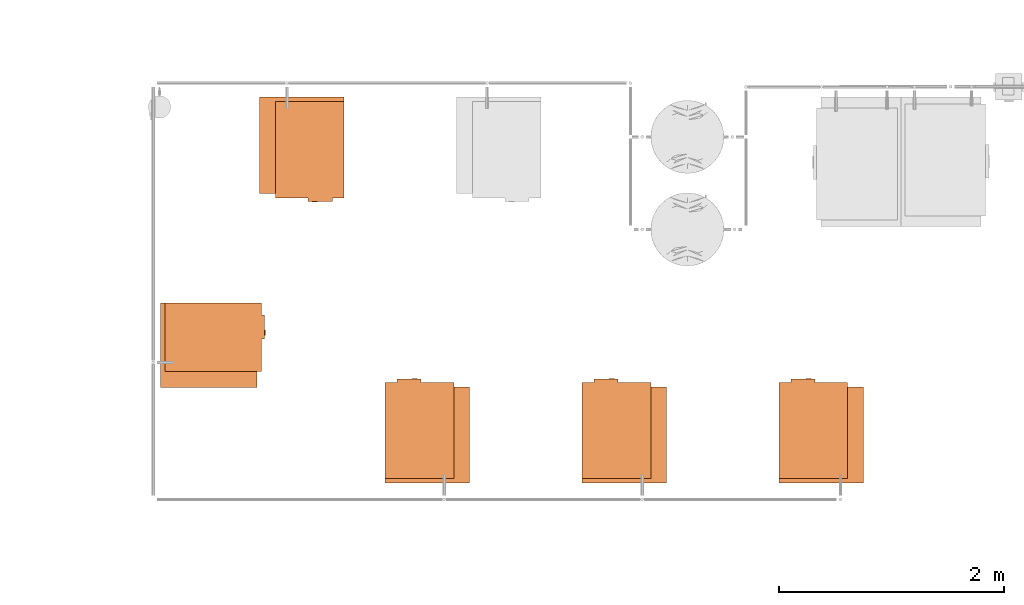
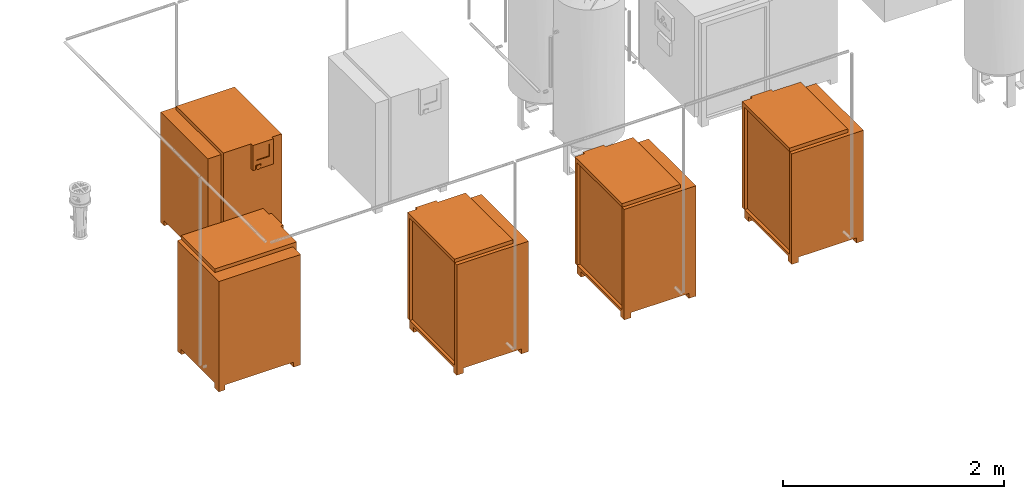
# One storey, part 325 of 331: 5 proxies.
"""IFC2X3 building model written with IfcOpenShell, lengths in millimetres."""

from ifc_helpers import new_model, entity, si_unit, converted_unit, derived_unit, direction, frame, origin, place, context, subcontext, project, spatial, faceted_brep, source, transform, mapped, material, material_list, type_object, type_shapes, element, save


model = new_model("IFC2X3")

# Units and contexts
model_context = context("Model", 3, precision=0.01, world=origin(), true_north=direction((6.12303176911189e-17, 1.0)))
body_context = subcontext(model_context, "Body", "Model", "MODEL_VIEW")
ifc_project = project(units=[si_unit("LENGTHUNIT", "METRE", prefix="MILLI"), si_unit("AREAUNIT", "SQUARE_METRE"), si_unit("VOLUMEUNIT", "CUBIC_METRE"), converted_unit("PLANEANGLEUNIT", "DEGREE", entity("IfcRatioMeasure", 0.0174532925199433), si_unit("PLANEANGLEUNIT", "RADIAN"), dimensions=[0, 0, 0, 0, 0, 0, 0]), si_unit("MASSUNIT", "GRAM", prefix="KILO"), derived_unit("MASSDENSITYUNIT", [(si_unit("MASSUNIT", "GRAM", prefix="KILO"), 1), (si_unit("LENGTHUNIT", "METRE"), -3)]), derived_unit("MOMENTOFINERTIAUNIT", [(si_unit("LENGTHUNIT", "METRE"), 4)]), si_unit("TIMEUNIT", "SECOND"), si_unit("FREQUENCYUNIT", "HERTZ"), si_unit("THERMODYNAMICTEMPERATUREUNIT", "DEGREE_CELSIUS"), derived_unit("THERMALTRANSMITTANCEUNIT", [(si_unit("MASSUNIT", "GRAM", prefix="KILO"), 1), (si_unit("THERMODYNAMICTEMPERATUREUNIT", "KELVIN"), -1), (si_unit("TIMEUNIT", "SECOND"), -3)]), derived_unit("VOLUMETRICFLOWRATEUNIT", [(si_unit("LENGTHUNIT", "METRE"), 3), (si_unit("TIMEUNIT", "SECOND"), -1)]), derived_unit("MASSFLOWRATEUNIT", [(si_unit("MASSUNIT", "GRAM", prefix="KILO"), 1), (si_unit("TIMEUNIT", "SECOND"), -1)]), derived_unit("ROTATIONALFREQUENCYUNIT", [(si_unit("TIMEUNIT", "SECOND"), -1)]), si_unit("ELECTRICCURRENTUNIT", "AMPERE"), si_unit("ELECTRICVOLTAGEUNIT", "VOLT"), si_unit("POWERUNIT", "WATT"), si_unit("FORCEUNIT", "NEWTON", prefix="KILO"), si_unit("ILLUMINANCEUNIT", "LUX"), si_unit("LUMINOUSFLUXUNIT", "LUMEN"), si_unit("LUMINOUSINTENSITYUNIT", "CANDELA"), derived_unit("USERDEFINED", [(si_unit("MASSUNIT", "GRAM", prefix="KILO"), -1), (si_unit("LENGTHUNIT", "METRE"), -2), (si_unit("TIMEUNIT", "SECOND"), 3), (si_unit("LUMINOUSFLUXUNIT", "LUMEN"), 1)]), derived_unit("LINEARVELOCITYUNIT", [(si_unit("LENGTHUNIT", "METRE"), 1), (si_unit("TIMEUNIT", "SECOND"), -1)]), si_unit("PRESSUREUNIT", "PASCAL"), derived_unit("USERDEFINED", [(si_unit("LENGTHUNIT", "METRE"), -2), (si_unit("MASSUNIT", "GRAM", prefix="KILO"), 1), (si_unit("TIMEUNIT", "SECOND"), -2)]), derived_unit("LINEARFORCEUNIT", [(si_unit("MASSUNIT", "GRAM", prefix="KILO"), 1), (si_unit("LENGTHUNIT", "METRE"), 1), (si_unit("TIMEUNIT", "SECOND"), -2), (si_unit("LENGTHUNIT", "METRE"), -1)]), derived_unit("PLANARFORCEUNIT", [(si_unit("MASSUNIT", "GRAM", prefix="KILO"), 1), (si_unit("LENGTHUNIT", "METRE"), 1), (si_unit("TIMEUNIT", "SECOND"), -2), (si_unit("LENGTHUNIT", "METRE"), -2)])], contexts=[model_context])

# Site, building, storey
site_placement = place(None, frame((0.0, -0.00077364408347762, 0.0)))
site = spatial("IfcSite", under=ifc_project, at=site_placement, CompositionType="ELEMENT")
building_placement = place(site_placement, origin())
building = spatial("IfcBuilding", under=site, at=building_placement, CompositionType="ELEMENT")
storey_placement = place(building_placement, origin())
storey = spatial("IfcBuildingStorey", under=building, at=storey_placement, CompositionType="ELEMENT", Elevation=0.0)

# Proxies
ifc_material_1 = material()
ifc_material_2 = material()
ifc_material_3 = material()
ifc_material_list_1 = material_list([ifc_material_1, ifc_material_2, ifc_material_3])
building_element_proxy_type = type_object("IfcBuildingElementProxyType", Name="SK 22:SK 22", PredefinedType="NOTDEFINED", material=ifc_material_1)
shared_shape = source(origin(), body_context, "Body", "Brep", [
    faceted_brep([(-407.500000000001, 235.0, 1220.0), (447.499999999999, 235.0, 1220.0), (447.5, 375.0, 1220.0), (-407.5, 375.0, 1220.0), (447.5, 375.0, 0.0), (447.5, 300.0, 0.0), (384.634472919975, 300.0, 0.0), (384.634472919975, 375.0, 0.0), (-407.500000000001, 235.0, 56.089418150774), (447.499999999999, 235.0, 56.089418150774), (447.499999999999, 300.0, 56.089418150774), (384.634472919975, 375.0, 56.089418150774), (-332.5, 375.0, 56.089418150774), (-332.5, 375.0, 0.0), (-407.5, 375.0, 0.0), (-407.5, 300.0, 0.0), (-407.5, 300.0, 56.089418150774), (-332.5, 300.0, 56.089418150774), (384.634472919975, 300.0, 56.089418150774), (-332.5, 300.0, 0.0)], [[[0, 1, 2, 3]], [[4, 5, 6, 7]], [[1, 0, 8, 9]], [[2, 1, 9, 10, 5, 4]], [[3, 2, 4, 7, 11, 12, 13, 14]], [[0, 3, 14, 15, 16, 8]], [[10, 9, 8, 16, 17, 12, 11, 18]], [[5, 10, 18, 6]], [[12, 17, 19, 13]], [[18, 11, 7, 6]], [[16, 15, 19, 17]], [[15, 14, 13, 19]]]),
    faceted_brep([(-483.897349584666, -118.970476127563, 982.237770655706), (-483.897349584666, -125.0, 984.735281218321), (-483.897349584666, -130.177669529664, 988.708246783269), (-483.897349584666, -134.150635094611, 993.885916312932), (-483.897349584666, -136.648145657227, 999.915440185369), (-483.897349584666, -137.5, 1006.38591631293), (-483.897349584666, -136.648145657227, 1012.8563924405), (-483.897349584666, -134.150635094611, 1018.88591631293), (-483.897349584666, -130.177669529664, 1024.0635858426), (-483.897349584666, -125.0, 1028.03655140754), (-483.897349584666, -118.970476127563, 1030.53406197016), (-483.897349584666, -112.5, 1031.38591631293), (-483.897349584666, -106.029523872437, 1030.53406197016), (-483.897349584666, -100.0, 1028.03655140754), (-483.897349584666, -94.8223304703364, 1024.0635858426), (-483.897349584666, -90.8493649053891, 1018.88591631293), (-483.897349584666, -88.3518543427734, 1012.8563924405), (-483.897349584666, -87.5, 1006.38591631293), (-483.897349584666, -88.3518543427733, 999.915440185369), (-483.897349584666, -90.849364905389, 993.885916312933), (-483.897349584666, -94.8223304703363, 988.708246783269), (-483.897349584666, -100.0, 984.735281218321), (-483.897349584666, -106.029523872437, 982.237770655706), (-483.897349584666, -112.5, 981.385916312932), (-477.500000000001, -118.970476127563, 1030.53406197016), (-477.500000000001, -125.0, 1028.03655140754), (-477.500000000001, -130.177669529664, 1024.0635858426), (-477.500000000001, -134.150635094611, 1018.88591631293), (-477.500000000001, -136.648145657227, 1012.8563924405), (-477.500000000001, -137.5, 1006.38591631293), (-477.500000000001, -136.648145657227, 999.915440185369), (-477.500000000001, -134.150635094611, 993.885916312932), (-477.500000000001, -130.177669529664, 988.708246783269), (-477.500000000001, -125.0, 984.735281218321), (-477.500000000001, -118.970476127563, 982.237770655706), (-477.500000000001, -112.5, 981.385916312932), (-477.500000000001, -106.029523872437, 982.237770655706), (-477.500000000001, -100.0, 984.735281218321), (-477.500000000001, -94.8223304703363, 988.708246783269), (-477.500000000001, -90.849364905389, 993.885916312933), (-477.500000000001, -88.3518543427733, 999.915440185369), (-477.500000000001, -87.5000000000001, 1006.38591631293), (-477.500000000001, -88.3518543427734, 1012.8563924405), (-477.500000000001, -90.8493649053891, 1018.88591631293), (-477.500000000001, -94.8223304703364, 1024.0635858426), (-477.500000000001, -100.0, 1028.03655140754), (-477.500000000001, -106.029523872437, 1030.53406197016), (-477.500000000001, -112.5, 1031.38591631293)], [[[0, 1, 2, 3, 4, 5, 6, 7, 8, 9, 10, 11, 12, 13, 14, 15, 16, 17, 18, 19, 20, 21, 22, 23]], [[24, 25, 26, 27, 28, 29, 30, 31, 32, 33, 34, 35, 36, 37, 38, 39, 40, 41, 42, 43, 44, 45, 46, 47]], [[40, 18, 17, 41]], [[39, 19, 18, 40]], [[21, 20, 38, 37]], [[39, 38, 20, 19]], [[22, 21, 37, 36]], [[23, 22, 36, 35]], [[34, 0, 23, 35]], [[33, 1, 0, 34]], [[3, 2, 32, 31]], [[33, 32, 2, 1]], [[4, 3, 31, 30]], [[5, 4, 30, 29]], [[28, 6, 5, 29]], [[27, 7, 6, 28]], [[9, 8, 26, 25]], [[27, 26, 8, 7]], [[10, 9, 25, 24]], [[11, 10, 24, 47]], [[46, 12, 11, 47]], [[45, 13, 12, 46]], [[15, 14, 44, 43]], [[45, 44, 14, 13]], [[16, 15, 43, 42]], [[17, 16, 42, 41]]]),
    faceted_brep([(-477.500000000001, -55.0, 1260.0), (-477.500000000001, -270.0, 1260.0), (-447.500000000001, -270.0, 1260.0), (-447.500000000001, -55.0, 1260.0), (-477.500000000001, -55.0, 981.385916312933), (-447.500000000001, -55.0, 981.385916312933), (-447.500000000001, -270.0, 981.385916312933), (-477.500000000001, -270.0, 981.385916312933), (-477.500000000001, -140.0, 981.385916312933), (-457.500000000001, -140.0, 981.385916312933), (-457.500000000001, -85.0, 981.385916312933), (-477.500000000001, -85.0, 981.385916312933), (-477.500000000001, -85.0, 1031.38591631293), (-477.500000000001, -140.0, 1031.38591631293), (-477.500000000001, -96.0179774809665, 1220.0), (-477.500000000001, -231.017977480966, 1220.0), (-477.500000000001, -231.017977480966, 1080.0), (-477.500000000001, -96.0179774809665, 1080.0), (-467.500000000001, -231.017977480966, 1220.0), (-467.500000000001, -96.0179774809666, 1220.0), (-467.500000000001, -96.0179774809665, 1080.0), (-467.500000000001, -231.017977480966, 1080.0), (-457.500000000001, -85.0, 1031.38591631293), (-457.500000000001, -140.0, 1031.38591631293)], [[[0, 1, 2, 3]], [[4, 5, 6, 7, 8, 9, 10, 11]], [[1, 0, 4, 11, 12, 13, 8, 7], [14, 15, 16, 17]], [[2, 1, 7, 6]], [[3, 2, 6, 5]], [[0, 3, 5, 4]], [[18, 19, 20, 21]], [[19, 18, 15, 14]], [[20, 19, 14, 17]], [[21, 20, 17, 16]], [[18, 21, 16, 15]], [[22, 10, 9, 23]], [[10, 22, 12, 11]], [[23, 9, 8, 13]], [[22, 23, 13, 12]]]),
    faceted_brep([(447.499999999998, -375.0, 1220.0), (447.499999999999, 235.0, 1220.0), (-407.500000000001, 235.0, 1220.0), (-407.500000000001, -342.939909824343, 1220.0), (407.5, -342.939909824343, 1220.0), (407.5, -375.0, 1220.0), (447.499999999998, -305.288454892349, 0.0), (447.499999999998, -375.0, 0.0), (384.634472919974, -375.0, 0.0), (384.634472919974, -305.288454892349, 0.0), (407.499999999998, -375.0, 88.1437175093115), (-407.500000000001, -375.0, 88.1437175093142), (-407.500000000001, -375.0, 0.0), (-332.500000000001, -375.0, 0.0), (-332.500000000001, -375.0, 56.089418150774), (384.634472919974, -375.0, 56.089418150774), (447.499999999998, -305.288454892349, 56.089418150774), (447.499999999999, 235.0, 56.089418150774), (-407.500000000001, 235.0, 56.089418150774), (-407.500000000001, -305.288454892347, 56.089418150774), (-407.500000000001, -305.288454892347, 0.0), (-407.500000000001, -342.939909824343, 88.1437175093142), (407.499999999998, -342.939909824343, 88.1437175093115), (384.634472919974, -305.288454892349, 56.089418150774), (-332.500000000001, -305.288454892347, 56.089418150774), (-332.500000000001, -305.288454892347, 0.0)], [[[0, 1, 2, 3, 4, 5]], [[6, 7, 8, 9]], [[7, 0, 5, 10, 11, 12, 13, 14, 15, 8]], [[1, 0, 7, 6, 16, 17]], [[2, 1, 17, 18]], [[3, 2, 18, 19, 20, 12, 11, 21]], [[21, 22, 4, 3]], [[22, 21, 11, 10]], [[4, 22, 10, 5]], [[17, 16, 23, 15, 14, 24, 19, 18]], [[20, 19, 24, 25]], [[24, 14, 13, 25]], [[15, 23, 9, 8]], [[16, 6, 9, 23]], [[12, 20, 25, 13]]]),
    faceted_brep([(407.5, 235.0, 1260.0), (-447.5, 235.0, 1260.0), (-447.500000000001, -375.0, 1260.0), (407.499999999998, -375.0, 1260.0), (-447.500000000001, -375.0, 88.1437175093128), (-447.5, 235.0, 88.1437175093128), (407.5, 235.0, 88.1437175093128), (407.499999999998, -342.939909824343, 88.1437175093128), (-407.5, -342.939909824343, 88.1437175093128), (-407.5, -375.0, 88.1437175093128), (-407.499999999999, -375.0, 1220.0), (407.499999999998, -375.0, 1220.0), (407.499999999998, -342.939909824343, 1220.0), (-407.499999999999, -342.939909824343, 1220.0)], [[[0, 1, 2, 3]], [[4, 5, 6, 7, 8, 9]], [[1, 0, 6, 5]], [[2, 1, 5, 4]], [[3, 2, 4, 9, 10, 11]], [[0, 3, 11, 12, 7, 6]], [[12, 13, 8, 7]], [[13, 12, 11, 10]], [[8, 13, 10, 9]]]),
])
type_shapes(building_element_proxy_type, [shared_shape])
proxy_1_placement = place(storey_placement, frame((46246.1118832776, -2985.00010169851, -700.0), z_axis=(0.0, 0.0, 1.0), x_axis=(-1.0, 0.0, 0.0)))
element("IfcBuildingElementProxy", 1, at=proxy_1_placement, inside=storey, type_object=building_element_proxy_type, material=ifc_material_list_1, Name="SK 22:SK 22", ObjectType="SK 22:SK 22", context=body_context, shape_type="MappedRepresentation", body=[
    mapped(shared_shape, transform((0.0, 0.0, 0.0), scale=1.0)),
])
ifc_material_list_2 = material_list([ifc_material_1, ifc_material_2, ifc_material_3])
proxy_2_placement = place(storey_placement, frame((47055.003616884, -1227.50010169851, -700.0), z_axis=(0.0, 0.0, 1.0), x_axis=(0.0, 1.0, 0.0)))
element("IfcBuildingElementProxy", 2, at=proxy_2_placement, inside=storey, type_object=building_element_proxy_type, material=ifc_material_list_2, Name="SK 22:SK 22", ObjectType="SK 22:SK 22", context=body_context, shape_type="MappedRepresentation", body=[
    mapped(shared_shape, transform((0.0, 0.0, 0.0), scale=1.0)),
])
ifc_material_list_3 = material_list([ifc_material_1, ifc_material_2, ifc_material_3])
proxy_3_placement = place(storey_placement, frame((48170.1085348189, -3762.50010169851, -700.0), z_axis=(0.0, 0.0, 1.0), x_axis=(0.0, -1.0, 0.0)))
element("IfcBuildingElementProxy", 3, at=proxy_3_placement, inside=storey, type_object=building_element_proxy_type, material=ifc_material_list_3, Name="SK 22:SK 22", ObjectType="SK 22:SK 22", context=body_context, shape_type="MappedRepresentation", body=[
    mapped(shared_shape, transform((0.0, 0.0, 0.0), scale=1.0)),
])
ifc_material_list_4 = material_list([ifc_material_1, ifc_material_2, ifc_material_3])
proxy_4_placement = place(storey_placement, frame((49920.1085348189, -3762.50010169852, -700.0), z_axis=(0.0, 0.0, 1.0), x_axis=(0.0, -1.0, 0.0)))
element("IfcBuildingElementProxy", 4, at=proxy_4_placement, inside=storey, type_object=building_element_proxy_type, material=ifc_material_list_4, Name="SK 22:SK 22", ObjectType="SK 22:SK 22", context=body_context, shape_type="MappedRepresentation", body=[
    mapped(shared_shape, transform((0.0, 0.0, 0.0), scale=1.0)),
])
ifc_material_list_5 = material_list([ifc_material_1, ifc_material_2, ifc_material_3])
proxy_5_placement = place(storey_placement, frame((51670.1085348189, -3762.50010169853, -700.0), z_axis=(0.0, 0.0, 1.0), x_axis=(0.0, -1.0, 0.0)))
element("IfcBuildingElementProxy", 5, at=proxy_5_placement, inside=storey, type_object=building_element_proxy_type, material=ifc_material_list_5, Name="SK 22:SK 22", ObjectType="SK 22:SK 22", context=body_context, shape_type="MappedRepresentation", body=[
    mapped(shared_shape, transform((0.0, 0.0, 0.0), scale=1.0)),
])

save(model, "model.ifc")
